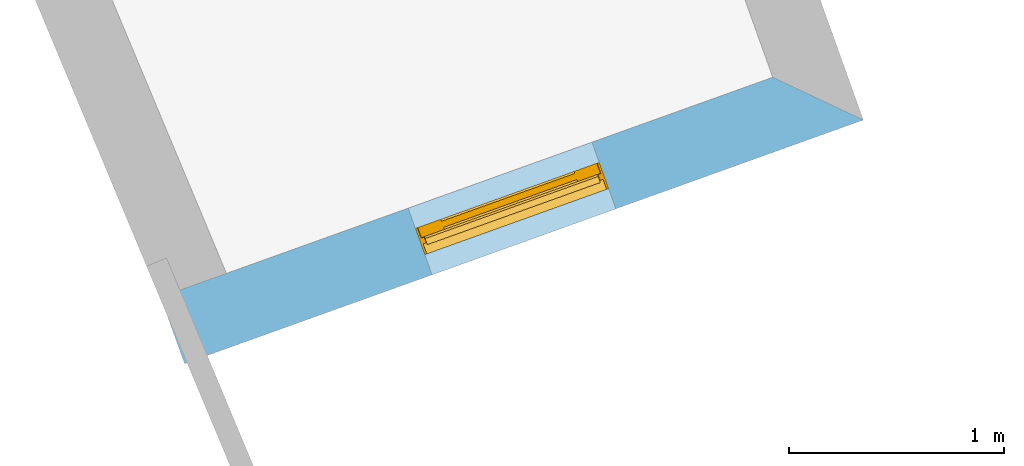
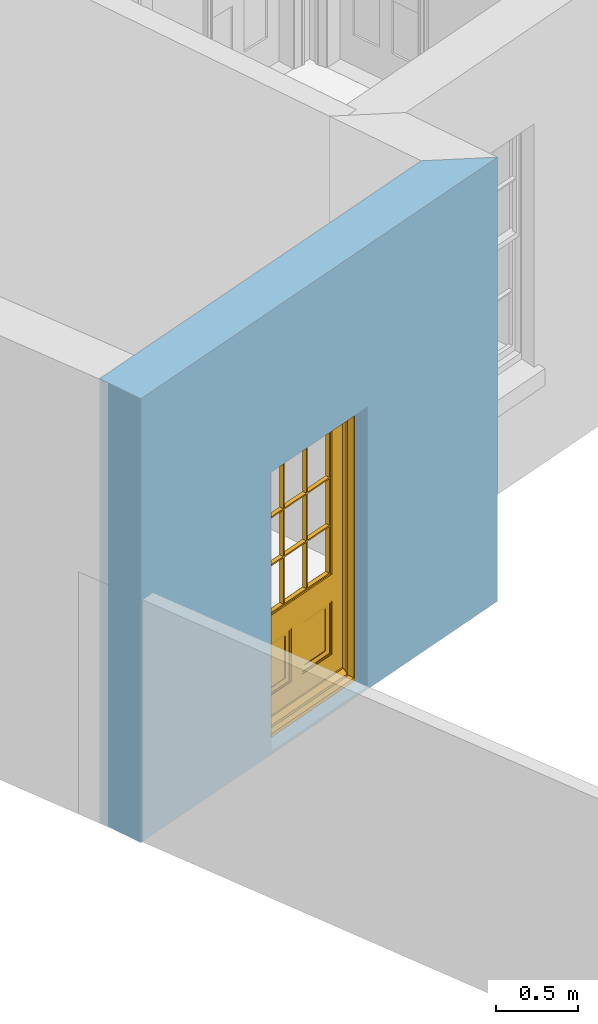
# One storey, part 2 of 10: 1 door, 1 opening, plus 1 element that does not belong to this part.
"""IFC2X3 building model written with IfcOpenShell, lengths in metres."""

from ifc_helpers import new_model, si_unit, frame, origin, place, context, subcontext, project, spatial, polyline, outline, extrude, faceted_brep, material, layer, layer_set, layer_usage, element, fill, save


model = new_model("IFC2X3")

# Units and contexts
model_context = context("Model", 3, world=origin())
body_context = subcontext(model_context, "Body", "Model", "MODEL_VIEW")
ifc_project = project(units=[si_unit("PLANEANGLEUNIT", "RADIAN"), si_unit("MASSUNIT", "GRAM", prefix="KILO"), si_unit("FORCEUNIT", "NEWTON", prefix="KILO"), si_unit("LENGTHUNIT", "METRE")], contexts=[model_context])

# Site, building, storey
site_placement = place(None, origin())
site = spatial("IfcSite", under=ifc_project, at=site_placement, CompositionType="ELEMENT")
building_placement = place(None, origin())
building = spatial("IfcBuilding", under=site, at=building_placement, Name="Building plot-9", CompositionType="ELEMENT")
storey_placement = place(None, frame((0.0, 0.0, 1.0)))
storey = spatial("IfcBuildingStorey", under=building, at=storey_placement, Name="Floor 0", CompositionType="ELEMENT", Elevation=1.0)

# Wall, opening, door
ifc_material = material(Name="Masonry")
ifc_layer = layer(ifc_material, 0.33, ventilated=False)
ifc_layer_set = layer_set([ifc_layer], Name="My Wall")
ifc_layer_usage = layer_usage(ifc_layer_set, "AXIS2", "NEGATIVE", 0.08)
wall_placement = place(storey_placement, origin())
wall = element("IfcWallStandardCase", 1, at=wall_placement, inside=storey, material=ifc_layer_usage, Name="exterior", context=body_context, shape_type="SweptSolid", body=[
    extrude(outline(polyline([(31.1651656744123, 12.8391071130311), (31.2766588517913, 12.5285120850639), (34.4384860645198, 13.6635018000555), (34.0163978591737, 13.8626036506437), (31.1651656744123, 12.8391071130311)])), origin(), (0.0, 0.0, 1.0), 3.3),
])
opening_placement = place(storey_placement, frame((0.0, 0.0, 0.02)))
opening = element("IfcOpeningElement", 2, at=opening_placement, cuts=wall, Name="Opening", ObjectType="Opening", context=body_context, shape_type="SweptSolid", body=[
    extrude(outline(polyline([(32.4293277983826, 12.9422815010221), (33.2858171179285, 13.2497323840973), (33.1743239405496, 13.5603274120645), (32.3178346210036, 13.2528765289893), (32.4293277983826, 12.9422815010221)])), origin(), (0.0, 0.0, 1.0), 2.08),
])
door_placement = place(storey_placement, frame((32.3448632700652, 13.1775807646336, 0.02), z_axis=(0.0, 0.0, 1.0), x_axis=(0.856489319545936, 0.30745088307525, 0.0)))
door = element("IfcDoor", 3, at=door_placement, inside=storey, Name="bedroom outside door", OverallHeight=2.08, OverallWidth=0.91, context=body_context, shape_type="Brep", held_by="IfcProductRepresentation", body=[
    faceted_brep([(0.545, -0.055, 0.265), (0.745, -0.055, 0.265), (0.745, -0.05, 0.265), (0.545, -0.05, 0.265), (0.745, -0.05, 0.58), (0.545, -0.05, 0.58), (0.545, -0.055, 0.58), (0.515, -0.06, 0.235), (0.775, -0.06, 0.235), (0.745, -0.055, 0.58), (0.515, -0.06, 0.61), (0.515, -0.065, 0.235), (0.775, -0.065, 0.235), (0.775, -0.06, 0.61), (0.515, -0.065, 0.61), (0.785, -0.065, 0.225), (0.505, -0.065, 0.225), (0.775, -0.065, 0.61), (0.505, -0.065, 0.62), (0.785, -0.065, 0.62), (0.505, -0.07, 0.225), (0.785, -0.07, 0.225), (0.505, -0.07, 0.62), (0.785, -0.07, 0.62), (0.883, -0.07, 0.075), (0.898, -0.07, 0.075), (0.405, -0.07, 0.62), (0.405, -0.07, 0.225), (0.027, -0.07, 0.075), (0.785, -0.07, 0.82), (0.125, -0.07, 0.82), (0.405, -0.065, 0.62), (0.405, -0.065, 0.225), (0.898, -0.07, 2.068), (0.027, -0.08, 0.075), (0.883, -0.08, 0.075), (0.125, -0.07, 0.225), (0.012, -0.07, 0.075), (0.785, -0.06, 0.82), (0.125, -0.06, 0.82), (0.125, -0.07, 0.62), (0.125, -0.065, 0.62), (0.395, -0.065, 0.61), (0.395, -0.065, 0.235), (0.125, -0.065, 0.225), (0.785, -0.07, 1.895), (0.027, -0.11, 0.045), (0.883, -0.11, 0.045), (0.558333, -0.06, 0.83), (0.351667, -0.06, 0.83), (0.125, -0.07, 1.895), (0.125, -0.06, 1.895), (0.785, -0.06, 1.895), (0.012, -0.07, 2.068), (0.135, -0.065, 0.61), (0.395, -0.06, 0.61), (0.395, -0.06, 0.235), (0.135, -0.065, 0.235), (0.027, -0.11, 0.027), (0.883, -0.11, 0.027), (0.568333, -0.06, 0.83), (0.558333, -0.03, 0.83), (0.351667, -0.03, 0.83), (0.341667, -0.06, 0.83), (0.135, -0.06, 1.185), (0.135, -0.06, 1.53), (0.775, -0.06, 1.53), (0.775, -0.06, 1.185), (0.135, -0.06, 0.61), (0.365, -0.055, 0.58), (0.365, -0.055, 0.265), (0.135, -0.06, 0.235), (0.568333, -0.06, 1.175), (0.558333, -0.06, 1.175), (0.775, -0.06, 0.83), (0.558333, -0.03, 1.175), (0.785, -0.03, 0.82), (0.125, -0.03, 0.82), (0.351667, -0.03, 1.175), (0.351667, -0.06, 1.175), (0.341667, -0.06, 1.175), (0.135, -0.06, 0.83), (0.135, -0.06, 1.175), (0.135, -0.03, 1.185), (0.135, -0.03, 1.53), (0.135, -0.06, 1.54), (0.351667, -0.06, 1.885), (0.558333, -0.06, 1.885), (0.775, -0.03, 1.53), (0.775, -0.03, 1.185), (0.775, -0.06, 1.175), (0.775, -0.06, 1.54), (0.165, -0.055, 0.58), (0.365, -0.05, 0.58), (0.365, -0.05, 0.265), (0.165, -0.055, 0.265), (0.568333, -0.03, 0.83), (0.568333, -0.03, 1.175), (0.568333, -0.06, 1.185), (0.558333, -0.06, 1.185), (0.775, -0.03, 0.83), (0.785, -0.02, 0.82), (0.125, -0.02, 0.82), (0.341667, -0.03, 0.83), (0.341667, -0.03, 1.175), (0.351667, -0.06, 1.185), (0.341667, -0.06, 1.185), (0.135, -0.03, 0.83), (0.341667, -0.03, 1.185), (0.125, -0.03, 1.895), (0.341667, -0.03, 1.53), (0.341667, -0.06, 1.53), (0.135, -0.06, 1.885), (0.341667, -0.06, 1.54), (0.341667, -0.06, 1.885), (0.558333, -0.03, 1.885), (0.351667, -0.03, 1.885), (0.568333, -0.06, 1.885), (0.785, -0.03, 1.895), (0.568333, -0.03, 1.185), (0.568333, -0.06, 1.53), (0.568333, -0.03, 1.53), (0.568333, -0.06, 1.54), (0.775, -0.06, 1.885), (0.165, -0.05, 0.58), (0.165, -0.05, 0.265), (0.775, -0.03, 1.175), (0.558333, -0.06, 1.53), (0.351667, -0.03, 1.185), (0.558333, -0.03, 1.185), (0.505, -0.02, 0.62), (0.405, -0.02, 0.62), (0.125, -0.02, 1.895), (0.785, -0.02, 1.895), (0.351667, -0.06, 1.53), (0.135, -0.03, 1.175), (0.135, -0.03, 1.54), (0.341667, -0.03, 1.54), (0.135, -0.03, 1.885), (0.351667, -0.06, 1.54), (0.558333, -0.03, 1.54), (0.558333, -0.06, 1.54), (0.351667, -0.03, 1.54), (0.775, -0.03, 1.54), (0.568333, -0.03, 1.54), (0.775, -0.03, 1.885), (0.558333, -0.03, 1.53), (0.405, -0.02, 0.225), (0.505, -0.02, 0.225), (0.125, -0.02, 0.62), (0.785, -0.02, 0.62), (0.012, -0.02, 2.068), (0.898, -0.02, 2.068), (0.351667, -0.03, 1.53), (0.341667, -0.03, 1.885), (0.568333, -0.03, 1.885), (0.405, -0.025, 0.225), (0.405, -0.025, 0.62), (0.505, -0.025, 0.62), (0.505, -0.025, 0.225), (0.898, -0.02, 0.027), (0.012, -0.02, 0.027), (0.125, -0.025, 0.62), (0.785, -0.025, 0.62), (0.395, -0.025, 0.235), (0.395, -0.025, 0.61), (0.125, -0.02, 0.225), (0.125, -0.025, 0.225), (0.515, -0.025, 0.61), (0.515, -0.025, 0.235), (0.785, -0.02, 0.225), (0.785, -0.025, 0.225), (0.135, -0.025, 0.61), (0.775, -0.025, 0.61), (0.135, -0.025, 0.235), (0.395, -0.03, 0.235), (0.395, -0.03, 0.61), (0.515, -0.03, 0.61), (0.515, -0.03, 0.235), (0.775, -0.025, 0.235), (0.135, -0.03, 0.61), (0.775, -0.03, 0.61), (0.135, -0.03, 0.235), (0.365, -0.035, 0.265), (0.365, -0.035, 0.58), (0.545, -0.035, 0.58), (0.545, -0.035, 0.265), (0.775, -0.03, 0.235), (0.165, -0.035, 0.58), (0.745, -0.035, 0.58), (0.165, -0.035, 0.265), (0.365, -0.04, 0.58), (0.365, -0.04, 0.265), (0.545, -0.04, 0.58), (0.545, -0.04, 0.265), (0.745, -0.035, 0.265), (0.165, -0.04, 0.58), (0.745, -0.04, 0.58), (0.165, -0.04, 0.265), (0.745, -0.04, 0.265), (0.885, -0.072, 0.025), (0.025, -0.072, 0.025), (0.025, -0.1, 0.025), (0.885, -0.1, 0.025), (0.9, -0.02, 0.025), (0.01, -0.02, 0.025), (0.9, -0.072, 0.025), (0.91, -0.02, 0.0), (0.0, -0.02, 0.0), (0.01, -0.072, 0.025), (0.9, -0.072, 2.07), (0.9, -0.02, 2.07), (0.885, -0.072, 2.055), (0.91, -0.02, 2.08), (0.01, -0.02, 2.07), (0.0, -0.02, 2.08), (0.01, -0.072, 2.07), (0.025, -0.072, 2.055), (0.0, -0.15, 2.08), (0.91, -0.15, 2.08), (0.01, -0.15, 2.07), (0.9, -0.15, 2.07), (0.01, -0.1, 2.07), (0.9, -0.1, 2.07), (0.0, -0.15, 0.0), (0.91, -0.15, 0.0), (0.01, -0.15, 0.025), (0.9, -0.15, 0.025), (0.01, -0.1, 0.025), (0.025, -0.1, 2.055), (0.9, -0.1, 0.025), (0.885, -0.1, 2.055), (0.898, -0.07, 0.027), (0.012, -0.07, 0.027), (0.883, -0.07, 0.027), (0.027, -0.07, 0.027)], [[[0, 1, 2, 3]], [[2, 4, 5, 3]], [[0, 3, 5, 6]], [[1, 0, 7, 8]], [[9, 4, 2, 1]], [[9, 6, 5, 4]], [[0, 6, 10, 7]], [[8, 7, 11, 12]], [[8, 13, 9, 1]], [[13, 10, 6, 9]], [[7, 10, 14, 11]], [[15, 12, 11, 16]], [[12, 17, 13, 8]], [[17, 14, 10, 13]], [[18, 16, 11, 14]], [[15, 19, 17, 12]], [[15, 16, 20, 21]], [[14, 17, 19, 18]], [[16, 18, 22, 20]], [[21, 23, 19, 15]], [[24, 25, 21, 20]], [[23, 22, 18, 19]], [[20, 22, 26, 27]], [[23, 21, 25]], [[28, 24, 20, 27]], [[22, 23, 29]], [[29, 30, 26, 22]], [[27, 26, 31, 32]], [[23, 25, 33, 29]], [[34, 35, 24, 28]], [[28, 27, 36, 37]], [[38, 39, 30, 29]], [[26, 30, 40]], [[26, 40, 41, 31]], [[42, 43, 32, 31]], [[32, 44, 36, 27]], [[33, 45, 29]], [[46, 47, 35, 34]], [[36, 40, 37]], [[39, 38, 48, 49]], [[50, 30, 39, 51]], [[29, 45, 52, 38]], [[53, 37, 40, 30]], [[44, 41, 40, 36]], [[31, 41, 54, 42]], [[43, 42, 55, 56]], [[57, 44, 32, 43]], [[50, 45, 33, 53]], [[47, 46, 58, 59]], [[60, 48, 38]], [[49, 48, 61, 62]], [[49, 63, 39]], [[50, 53, 30]], [[51, 39, 64, 65]], [[45, 50, 51, 52]], [[66, 67, 38, 52]], [[57, 54, 41, 44]], [[42, 54, 68, 55]], [[56, 55, 69, 70]], [[56, 71, 57, 43]], [[60, 72, 73, 48]], [[60, 38, 74]], [[48, 73, 75, 61]], [[76, 77, 62, 61]], [[62, 78, 79, 49]], [[49, 79, 80, 63]], [[63, 81, 39]], [[82, 64, 39]], [[65, 64, 83, 84]], [[85, 51, 65]], [[52, 51, 86, 87]], [[88, 89, 67, 66]], [[90, 38, 67]], [[91, 66, 52]], [[71, 68, 54, 57]], [[55, 68, 92, 69]], [[69, 93, 94, 70]], [[70, 95, 71, 56]], [[96, 97, 72, 60]], [[73, 72, 98, 99]], [[74, 38, 90]], [[100, 96, 60, 74]], [[75, 73, 79, 78]], [[61, 75, 97, 96]], [[101, 102, 77, 76]], [[77, 103, 62]], [[96, 76, 61]], [[103, 104, 78, 62]], [[80, 79, 105, 106]], [[63, 80, 104, 103]], [[81, 63, 103, 107]], [[81, 82, 39]], [[106, 64, 82, 80]], [[106, 108, 83, 64]], [[84, 83, 77, 109]], [[110, 111, 65, 84]], [[112, 51, 85]], [[113, 85, 65, 111]], [[114, 86, 51]], [[115, 87, 86, 116]], [[117, 52, 87]], [[118, 76, 89, 88]], [[119, 98, 67, 89]], [[120, 121, 88, 66]], [[67, 98, 72, 90]], [[91, 122, 120, 66]], [[91, 52, 123]], [[95, 92, 68, 71]], [[69, 92, 124, 93]], [[94, 93, 124, 125]], [[94, 125, 95, 70]], [[72, 97, 126, 90]], [[127, 99, 98, 120]], [[99, 105, 79, 73]], [[74, 90, 126, 100]], [[96, 100, 76]], [[128, 129, 75, 78]], [[97, 75, 129, 119]], [[130, 131, 102, 101]], [[109, 77, 102, 132]], [[133, 101, 76, 118]], [[77, 107, 103]], [[78, 104, 108, 128]], [[111, 106, 105, 134]], [[104, 80, 82, 135]], [[107, 135, 82, 81]], [[110, 108, 106, 111]], [[104, 135, 83, 108]], [[83, 135, 77]], [[136, 84, 109]], [[110, 84, 136, 137]], [[114, 51, 112]], [[85, 136, 138, 112]], [[113, 137, 136, 85]], [[111, 134, 139, 113]], [[86, 114, 113, 139]], [[140, 141, 87, 115]], [[139, 142, 116, 86]], [[109, 118, 115, 116]], [[117, 123, 52]], [[117, 87, 141, 122]], [[126, 89, 76]], [[143, 118, 88]], [[120, 98, 119, 121]], [[119, 89, 126, 97]], [[144, 143, 88, 121]], [[144, 122, 91, 143]], [[127, 120, 122, 141]], [[143, 91, 123, 145]], [[124, 92, 95, 125]], [[146, 129, 99, 127]], [[99, 129, 128, 105]], [[100, 126, 76]], [[121, 119, 129, 146]], [[147, 131, 130, 148]], [[131, 149, 102]], [[130, 101, 150]], [[102, 151, 132]], [[118, 109, 132, 133]], [[101, 133, 152]], [[107, 77, 135]], [[153, 128, 108, 110]], [[134, 105, 128, 153]], [[109, 138, 136]], [[153, 110, 137, 142]], [[154, 114, 112, 138]], [[137, 113, 114, 154]], [[141, 139, 134, 127]], [[141, 140, 142, 139]], [[144, 140, 115, 155]], [[142, 137, 154, 116]], [[155, 115, 118]], [[116, 154, 109]], [[117, 155, 145, 123]], [[122, 144, 155, 117]], [[143, 145, 118]], [[121, 146, 140, 144]], [[146, 127, 134, 153]], [[156, 157, 131, 147]], [[148, 130, 158, 159]], [[148, 160, 161, 147]], [[157, 162, 149, 131]], [[161, 151, 102, 149]], [[101, 152, 160, 150]], [[163, 158, 130, 150]], [[151, 152, 133, 132]], [[154, 138, 109]], [[142, 140, 146, 153]], [[145, 155, 118]], [[157, 156, 164, 165]], [[147, 166, 167, 156]], [[168, 169, 159, 158]], [[170, 148, 159, 171]], [[148, 170, 160]], [[166, 147, 161]], [[172, 162, 157, 165]], [[166, 149, 162, 167]], [[166, 161, 149]], [[150, 160, 170]], [[163, 173, 168, 158]], [[171, 163, 150, 170]], [[174, 164, 156, 167]], [[175, 176, 165, 164]], [[169, 168, 177, 178]], [[171, 159, 169, 179]], [[167, 162, 172, 174]], [[176, 180, 172, 165]], [[179, 173, 163, 171]], [[181, 177, 168, 173]], [[164, 174, 182, 175]], [[183, 184, 176, 175]], [[178, 177, 185, 186]], [[179, 169, 178, 187]], [[174, 172, 180, 182]], [[184, 188, 180, 176]], [[187, 181, 173, 179]], [[189, 185, 177, 181]], [[175, 182, 190, 183]], [[191, 184, 183, 192]], [[185, 193, 194, 186]], [[187, 178, 186, 195]], [[182, 180, 188, 190]], [[191, 196, 188, 184]], [[195, 189, 181, 187]], [[197, 193, 185, 189]], [[183, 190, 198, 192]], [[198, 196, 191, 192]], [[194, 193, 197, 199]], [[195, 186, 194, 199]], [[188, 196, 198, 190]], [[197, 189, 195, 199]], [[200, 201, 202, 203]], [[201, 200, 204, 205]], [[206, 204, 200]], [[204, 207, 208, 205]], [[209, 201, 205]], [[210, 211, 204, 206]], [[206, 200, 212, 210]], [[211, 213, 207, 204]], [[214, 205, 208, 215]], [[216, 217, 201, 209]], [[205, 214, 216, 209]], [[216, 214, 211, 210]], [[210, 212, 217, 216]], [[214, 215, 213, 211]], [[218, 219, 213, 215]], [[219, 218, 220, 221]], [[221, 220, 222, 223]], [[215, 208, 224, 218]], [[225, 224, 208, 207]], [[224, 226, 220, 218]], [[224, 225, 227, 226]], [[219, 225, 207, 213]], [[228, 222, 220, 226]], [[219, 221, 227, 225]], [[226, 227, 203, 202]], [[202, 229, 222, 228]], [[228, 226, 202]], [[227, 221, 223, 230]], [[230, 203, 227]], [[217, 229, 202, 201]], [[231, 223, 222, 229]], [[230, 223, 231, 203]], [[231, 229, 217, 212]], [[212, 200, 203, 231]], [[33, 152, 151, 53]], [[25, 160, 152, 33]], [[161, 37, 53, 151]], [[232, 160, 25]], [[161, 233, 37]], [[160, 232, 234]], [[24, 234, 232, 25]], [[233, 161, 235]], [[37, 233, 235, 28]], [[161, 160, 234, 235]], [[35, 47, 234, 24]], [[28, 235, 46, 34]], [[58, 235, 234, 59]], [[59, 234, 47]], [[58, 46, 235]]]),
])
fill(opening, door)

save(model, "model.ifc")
